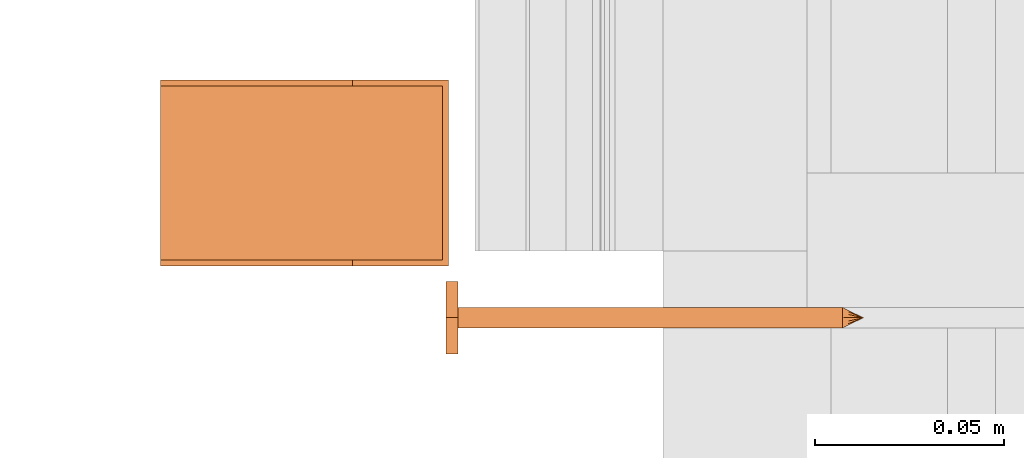
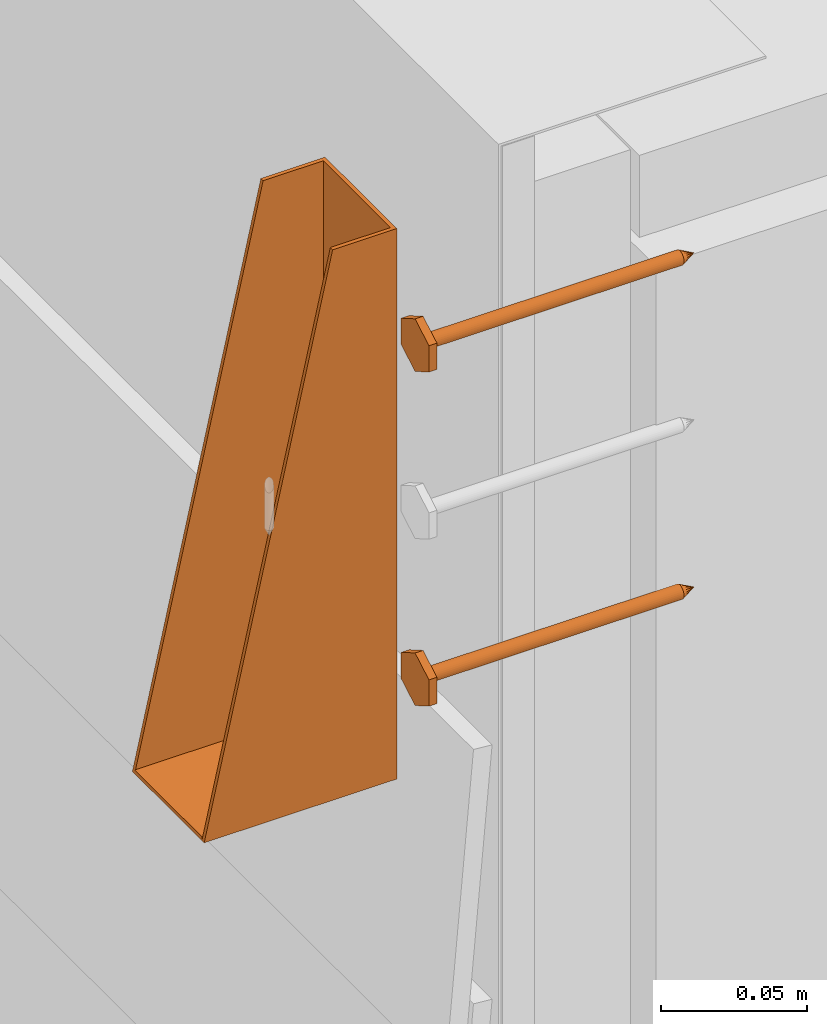
# One storey, part 17 of 44: 3 proxies.
"""IFC4 building model written with IfcOpenShell, lengths in feet."""

from ifc_helpers import new_model, entity, si_unit, converted_unit, derived_unit, direction, frame, frame_2d, origin, origin_2d_with_axis, place, context, subcontext, project, spatial, polyline, rectangle, outline, extrude, source, transform, mapped, material, type_object, type_shapes, element, save


model = new_model("IFC4")

# Units and contexts
model_context = context("Model", 3, precision=0.0001, world=origin(), true_north=direction((6.12303176911189e-17, 1.0)))
body_context = subcontext(model_context, "Body", "Model", "MODEL_VIEW")
ifc_project = project(units=[converted_unit("LENGTHUNIT", "FOOT", entity("IfcRatioMeasure", 0.3048), si_unit("LENGTHUNIT", "METRE"), dimensions=[1, 0, 0, 0, 0, 0, 0]), converted_unit("AREAUNIT", "SQUARE FOOT", entity("IfcRatioMeasure", 0.09290304), si_unit("AREAUNIT", "SQUARE_METRE"), dimensions=[2, 0, 0, 0, 0, 0, 0]), converted_unit("VOLUMEUNIT", "CUBIC FOOT", entity("IfcRatioMeasure", 0.028316846592), si_unit("VOLUMEUNIT", "CUBIC_METRE"), dimensions=[3, 0, 0, 0, 0, 0, 0]), converted_unit("PLANEANGLEUNIT", "DEGREE", entity("IfcRatioMeasure", 0.0174532925199433), si_unit("PLANEANGLEUNIT", "RADIAN"), dimensions=[0, 0, 0, 0, 0, 0, 0]), si_unit("MASSUNIT", "GRAM", prefix="KILO"), derived_unit("MASSDENSITYUNIT", [(si_unit("MASSUNIT", "GRAM", prefix="KILO"), 1), (si_unit("LENGTHUNIT", "METRE"), -3)]), derived_unit("MOMENTOFINERTIAUNIT", [(si_unit("LENGTHUNIT", "METRE"), 4)]), si_unit("TIMEUNIT", "SECOND"), si_unit("FREQUENCYUNIT", "HERTZ"), si_unit("THERMODYNAMICTEMPERATUREUNIT", "DEGREE_CELSIUS"), derived_unit("THERMALTRANSMITTANCEUNIT", [(si_unit("MASSUNIT", "GRAM", prefix="KILO"), 1), (si_unit("THERMODYNAMICTEMPERATUREUNIT", "KELVIN"), -1), (si_unit("TIMEUNIT", "SECOND"), -3)]), derived_unit("VOLUMETRICFLOWRATEUNIT", [(si_unit("LENGTHUNIT", "METRE"), 3), (si_unit("TIMEUNIT", "SECOND"), -1)]), si_unit("ELECTRICCURRENTUNIT", "AMPERE"), si_unit("ELECTRICVOLTAGEUNIT", "VOLT"), si_unit("POWERUNIT", "WATT"), si_unit("FORCEUNIT", "NEWTON"), si_unit("ILLUMINANCEUNIT", "LUX"), si_unit("LUMINOUSFLUXUNIT", "LUMEN"), si_unit("LUMINOUSINTENSITYUNIT", "CANDELA"), derived_unit("USERDEFINED", [(si_unit("MASSUNIT", "GRAM", prefix="KILO"), -1), (si_unit("LENGTHUNIT", "METRE"), -2), (si_unit("TIMEUNIT", "SECOND"), 3), (si_unit("LUMINOUSFLUXUNIT", "LUMEN"), 1)]), derived_unit("LINEARVELOCITYUNIT", [(si_unit("LENGTHUNIT", "METRE"), 1), (si_unit("TIMEUNIT", "SECOND"), -1)]), si_unit("PRESSUREUNIT", "PASCAL"), derived_unit("USERDEFINED", [(si_unit("LENGTHUNIT", "METRE"), -2), (si_unit("MASSUNIT", "GRAM", prefix="KILO"), 1), (si_unit("TIMEUNIT", "SECOND"), -2)]), derived_unit("LINEARFORCEUNIT", [(si_unit("MASSUNIT", "GRAM", prefix="KILO"), 1), (si_unit("LENGTHUNIT", "METRE"), 1), (si_unit("TIMEUNIT", "SECOND"), -2), (si_unit("LENGTHUNIT", "METRE"), -1)]), derived_unit("PLANARFORCEUNIT", [(si_unit("MASSUNIT", "GRAM", prefix="KILO"), 1), (si_unit("LENGTHUNIT", "METRE"), 1), (si_unit("TIMEUNIT", "SECOND"), -2), (si_unit("LENGTHUNIT", "METRE"), -2)])], contexts=[model_context])

# Site, building, storey
site_placement = place(None, origin())
site = spatial("IfcSite", under=ifc_project, at=site_placement, CompositionType="ELEMENT")
building_placement = place(site_placement, origin())
building = spatial("IfcBuilding", under=site, at=building_placement, CompositionType="ELEMENT")
storey_placement = place(building_placement, origin())
storey = spatial("IfcBuildingStorey", under=building, at=storey_placement, CompositionType="ELEMENT", Elevation=0.0)

# Proxies
ifc_material_1 = material(Name="STRONG-DRIVE TIMBER SCREW (EXTERIOR GRADE)", Category="Materials")
building_element_proxy_type_1 = type_object("IfcBuildingElementProxyType", PredefinedType="NOTDEFINED", material=ifc_material_1)
cartesian_point_1 = entity("IfcCartesianPoint", [0.0, -0.00916666666677942, -0.333333333333231])
vertex_point_1 = entity("IfcVertexPoint", cartesian_point_1)
cartesian_point_2 = entity("IfcCartesianPoint", [0.0, 0.00916666666667798, -0.333333333333232])
vertex_point_2 = entity("IfcVertexPoint", cartesian_point_2)
cartesian_point_3 = entity("IfcCartesianPoint", [0.0, 0.0, -0.333333333333232])
ifc_direction_1 = entity("IfcDirection", [0.0, 0.0, 1.0])
ifc_direction_2 = entity("IfcDirection", [0.0, 1.0, 0.0])
edge_curve_1 = entity("IfcEdgeCurve", vertex_point_1, vertex_point_2, entity("IfcTrimmedCurve", entity("IfcCircle", entity("IfcAxis2Placement3D", cartesian_point_3, ifc_direction_1, ifc_direction_2), 0.0091666666667287), [cartesian_point_1], [cartesian_point_2], True, "CARTESIAN"), True)
vertex_point_3 = entity("IfcVertexPoint", cartesian_point_3)
ifc_direction_3 = entity("IfcDirection", [0.0, -1.0, 0.0])
edge_curve_2 = entity("IfcEdgeCurve", vertex_point_2, vertex_point_3, entity("IfcTrimmedCurve", entity("IfcLine", cartesian_point_2, entity("IfcVector", ifc_direction_3, 1.0)), [cartesian_point_2], [cartesian_point_3], True, "CARTESIAN"), True)
edge_curve_3 = entity("IfcEdgeCurve", vertex_point_3, vertex_point_1, entity("IfcTrimmedCurve", entity("IfcLine", cartesian_point_3, entity("IfcVector", ifc_direction_3, 1.0)), [cartesian_point_3], [cartesian_point_1], True, "CARTESIAN"), True)
edge_curve_4 = entity("IfcEdgeCurve", vertex_point_2, vertex_point_1, entity("IfcTrimmedCurve", entity("IfcCircle", entity("IfcAxis2Placement3D", cartesian_point_3, ifc_direction_1, ifc_direction_2), 0.0091666666667287), [cartesian_point_2], [cartesian_point_1], True, "CARTESIAN"), True)
cartesian_point_4 = entity("IfcCartesianPoint", [0.0, 0.0, -0.351666666666333])
vertex_point_4 = entity("IfcVertexPoint", cartesian_point_4)
edge_curve_5 = entity("IfcEdgeCurve", vertex_point_4, vertex_point_2, entity("IfcTrimmedCurve", entity("IfcLine", cartesian_point_4, entity("IfcVector", entity("IfcDirection", [0.0, 0.447213595507238, 0.894427190996276]), 1.0)), [cartesian_point_4], [cartesian_point_2], True, "CARTESIAN"), True)
edge_curve_6 = entity("IfcEdgeCurve", vertex_point_1, vertex_point_4, entity("IfcTrimmedCurve", entity("IfcLine", cartesian_point_1, entity("IfcVector", entity("IfcDirection", [0.0, 0.447213595507224, -0.894427190996283]), 1.0)), [cartesian_point_1], [cartesian_point_4], True, "CARTESIAN"), True)
cartesian_point_5 = entity("IfcCartesianPoint", [-0.00916666666669726, 0.0, -0.333333333333231])
cartesian_point_6 = entity("IfcCartesianPoint", [0.0, 0.0, -0.338202184590857])
ifc_direction_4 = entity("IfcDirection", [0.0, 0.0, -1.0])
cartesian_point_7 = entity("IfcCartesianPoint", [-0.0312499999999625, 0.0180421959120341, 0.0104166666670403])
vertex_point_5 = entity("IfcVertexPoint", cartesian_point_7)
cartesian_point_8 = entity("IfcCartesianPoint", [-0.0312499999999625, -0.0180421959123371, 0.0104166666670405])
vertex_point_6 = entity("IfcVertexPoint", cartesian_point_8)
ifc_direction_5 = entity("IfcDirection", [0.0, -1.0, 0.0])
edge_curve_7 = entity("IfcEdgeCurve", vertex_point_5, vertex_point_6, entity("IfcTrimmedCurve", entity("IfcLine", cartesian_point_7, entity("IfcVector", ifc_direction_5, 1.0)), [cartesian_point_7], [cartesian_point_8], True, "CARTESIAN"), True)
cartesian_point_9 = entity("IfcCartesianPoint", [0.0, -0.0360843918245031, 0.0104166666670406])
vertex_point_7 = entity("IfcVertexPoint", cartesian_point_9)
edge_curve_8 = entity("IfcEdgeCurve", vertex_point_6, vertex_point_7, entity("IfcTrimmedCurve", entity("IfcLine", cartesian_point_8, entity("IfcVector", entity("IfcDirection", [0.866025403784438, -0.500000000000001, 0.0]), 1.0)), [cartesian_point_8], [cartesian_point_9], True, "CARTESIAN"), True)
cartesian_point_10 = entity("IfcCartesianPoint", [0.0312500000000785, -0.0180421959122939, 0.0104166666670405])
vertex_point_8 = entity("IfcVertexPoint", cartesian_point_10)
edge_curve_9 = entity("IfcEdgeCurve", vertex_point_7, vertex_point_8, entity("IfcTrimmedCurve", entity("IfcLine", cartesian_point_9, entity("IfcVector", entity("IfcDirection", [0.86602540378444, 0.499999999999998, 0.0]), 1.0)), [cartesian_point_9], [cartesian_point_10], True, "CARTESIAN"), True)
cartesian_point_11 = entity("IfcCartesianPoint", [0.0312500000000786, 0.0180421959119906, 0.0104166666670403])
vertex_point_9 = entity("IfcVertexPoint", cartesian_point_11)
ifc_direction_6 = entity("IfcDirection", [0.0, 1.0, 0.0])
edge_curve_10 = entity("IfcEdgeCurve", vertex_point_8, vertex_point_9, entity("IfcTrimmedCurve", entity("IfcLine", cartesian_point_10, entity("IfcVector", ifc_direction_6, 1.0)), [cartesian_point_10], [cartesian_point_11], True, "CARTESIAN"), True)
cartesian_point_12 = entity("IfcCartesianPoint", [0.0, 0.0360843918242001, 0.0104166666670402])
vertex_point_10 = entity("IfcVertexPoint", cartesian_point_12)
edge_curve_11 = entity("IfcEdgeCurve", vertex_point_9, vertex_point_10, entity("IfcTrimmedCurve", entity("IfcLine", cartesian_point_11, entity("IfcVector", entity("IfcDirection", [-0.866025403784436, 0.500000000000004, 0.0]), 1.0)), [cartesian_point_11], [cartesian_point_12], True, "CARTESIAN"), True)
edge_curve_12 = entity("IfcEdgeCurve", vertex_point_10, vertex_point_5, entity("IfcTrimmedCurve", entity("IfcLine", cartesian_point_12, entity("IfcVector", entity("IfcDirection", [-0.866025403784438, -0.500000000000001, 0.0]), 1.0)), [cartesian_point_12], [cartesian_point_7], True, "CARTESIAN"), True)
ifc_direction_7 = entity("IfcDirection", [0.0, 0.0, 1.0])
cartesian_point_13 = entity("IfcCartesianPoint", [-0.0312499999999625, 0.018042195912034, 0.0])
vertex_point_11 = entity("IfcVertexPoint", cartesian_point_13)
cartesian_point_14 = entity("IfcCartesianPoint", [0.0, 0.0360843918242001, 0.0])
vertex_point_12 = entity("IfcVertexPoint", cartesian_point_14)
edge_curve_13 = entity("IfcEdgeCurve", vertex_point_11, vertex_point_12, entity("IfcTrimmedCurve", entity("IfcLine", cartesian_point_13, entity("IfcVector", entity("IfcDirection", [0.866025403784438, 0.500000000000001, 0.0]), 1.0)), [cartesian_point_13], [cartesian_point_14], True, "CARTESIAN"), True)
cartesian_point_15 = entity("IfcCartesianPoint", [0.0312500000000786, 0.0180421959119905, 0.0])
vertex_point_13 = entity("IfcVertexPoint", cartesian_point_15)
edge_curve_14 = entity("IfcEdgeCurve", vertex_point_12, vertex_point_13, entity("IfcTrimmedCurve", entity("IfcLine", cartesian_point_14, entity("IfcVector", entity("IfcDirection", [0.866025403784437, -0.500000000000004, 0.0]), 1.0)), [cartesian_point_14], [cartesian_point_15], True, "CARTESIAN"), True)
cartesian_point_16 = entity("IfcCartesianPoint", [0.0312500000000785, -0.0180421959122939, 0.0])
vertex_point_14 = entity("IfcVertexPoint", cartesian_point_16)
edge_curve_15 = entity("IfcEdgeCurve", vertex_point_13, vertex_point_14, entity("IfcTrimmedCurve", entity("IfcLine", cartesian_point_15, entity("IfcVector", ifc_direction_5, 1.0)), [cartesian_point_15], [cartesian_point_16], True, "CARTESIAN"), True)
cartesian_point_17 = entity("IfcCartesianPoint", [0.0, -0.0360843918245032, 0.0])
vertex_point_15 = entity("IfcVertexPoint", cartesian_point_17)
edge_curve_16 = entity("IfcEdgeCurve", vertex_point_14, vertex_point_15, entity("IfcTrimmedCurve", entity("IfcLine", cartesian_point_16, entity("IfcVector", entity("IfcDirection", [-0.86602540378444, -0.499999999999998, 0.0]), 1.0)), [cartesian_point_16], [cartesian_point_17], True, "CARTESIAN"), True)
cartesian_point_18 = entity("IfcCartesianPoint", [-0.0312499999999625, -0.0180421959123372, 0.0])
vertex_point_16 = entity("IfcVertexPoint", cartesian_point_18)
edge_curve_17 = entity("IfcEdgeCurve", vertex_point_15, vertex_point_16, entity("IfcTrimmedCurve", entity("IfcLine", cartesian_point_17, entity("IfcVector", entity("IfcDirection", [-0.866025403784438, 0.500000000000001, 0.0]), 1.0)), [cartesian_point_17], [cartesian_point_18], True, "CARTESIAN"), True)
edge_curve_18 = entity("IfcEdgeCurve", vertex_point_16, vertex_point_11, entity("IfcTrimmedCurve", entity("IfcLine", cartesian_point_18, entity("IfcVector", ifc_direction_6, 1.0)), [cartesian_point_18], [cartesian_point_13], True, "CARTESIAN"), True)
ifc_direction_8 = entity("IfcDirection", [0.0, 0.0, -1.0])
edge_curve_19 = entity("IfcEdgeCurve", vertex_point_5, vertex_point_11, entity("IfcTrimmedCurve", entity("IfcLine", cartesian_point_7, entity("IfcVector", ifc_direction_8, 1.0)), [cartesian_point_7], [cartesian_point_13], True, "CARTESIAN"), True)
edge_curve_20 = entity("IfcEdgeCurve", vertex_point_16, vertex_point_6, entity("IfcTrimmedCurve", entity("IfcLine", cartesian_point_8, entity("IfcVector", ifc_direction_7, 1.0)), [cartesian_point_18], [cartesian_point_8], True, "CARTESIAN"), True)
edge_curve_21 = entity("IfcEdgeCurve", vertex_point_15, vertex_point_7, entity("IfcTrimmedCurve", entity("IfcLine", cartesian_point_9, entity("IfcVector", ifc_direction_7, 1.0)), [cartesian_point_17], [cartesian_point_9], True, "CARTESIAN"), True)
edge_curve_22 = entity("IfcEdgeCurve", vertex_point_14, vertex_point_8, entity("IfcTrimmedCurve", entity("IfcLine", cartesian_point_10, entity("IfcVector", ifc_direction_7, 1.0)), [cartesian_point_16], [cartesian_point_10], True, "CARTESIAN"), True)
edge_curve_23 = entity("IfcEdgeCurve", vertex_point_13, vertex_point_9, entity("IfcTrimmedCurve", entity("IfcLine", cartesian_point_11, entity("IfcVector", ifc_direction_7, 1.0)), [cartesian_point_15], [cartesian_point_11], True, "CARTESIAN"), True)
edge_curve_24 = entity("IfcEdgeCurve", vertex_point_12, vertex_point_10, entity("IfcTrimmedCurve", entity("IfcLine", cartesian_point_12, entity("IfcVector", ifc_direction_7, 1.0)), [cartesian_point_14], [cartesian_point_12], True, "CARTESIAN"), True)
cartesian_point_19 = entity("IfcCartesianPoint", [0.0, -0.00916666666682102, 0.0])
vertex_point_17 = entity("IfcVertexPoint", cartesian_point_19)
cartesian_point_20 = entity("IfcCartesianPoint", [0.0, 0.00916666666651231, 0.0])
vertex_point_18 = entity("IfcVertexPoint", cartesian_point_20)
cartesian_point_21 = entity("IfcCartesianPoint", [0.0, 0.0, 0.0])
ifc_direction_9 = entity("IfcDirection", [0.0, 0.0, 1.0])
ifc_direction_10 = entity("IfcDirection", [0.0, 1.0, 0.0])
edge_curve_25 = entity("IfcEdgeCurve", vertex_point_17, vertex_point_18, entity("IfcTrimmedCurve", entity("IfcCircle", entity("IfcAxis2Placement3D", cartesian_point_21, ifc_direction_9, ifc_direction_10), 0.00916666666666667), [cartesian_point_19], [cartesian_point_20], True, "CARTESIAN"), True)
edge_curve_26 = entity("IfcEdgeCurve", vertex_point_18, vertex_point_17, entity("IfcTrimmedCurve", entity("IfcCircle", entity("IfcAxis2Placement3D", cartesian_point_21, ifc_direction_9, ifc_direction_10), 0.00916666666666667), [cartesian_point_20], [cartesian_point_19], True, "CARTESIAN"), True)
cartesian_point_22 = entity("IfcCartesianPoint", [0.0, -0.00916666666682389, -0.333333333333339])
vertex_point_19 = entity("IfcVertexPoint", cartesian_point_22)
cartesian_point_23 = entity("IfcCartesianPoint", [0.0, 0.00916666666650944, -0.333333333333339])
vertex_point_20 = entity("IfcVertexPoint", cartesian_point_23)
cartesian_point_24 = entity("IfcCartesianPoint", [0.0, 0.0, -0.333333333333339])
ifc_direction_11 = entity("IfcDirection", [0.0, 0.0, -1.0])
edge_curve_27 = entity("IfcEdgeCurve", vertex_point_19, vertex_point_20, entity("IfcTrimmedCurve", entity("IfcCircle", entity("IfcAxis2Placement3D", cartesian_point_24, ifc_direction_11, ifc_direction_10), 0.00916666666666667), [cartesian_point_22], [cartesian_point_23], True, "CARTESIAN"), True)
edge_curve_28 = entity("IfcEdgeCurve", vertex_point_20, vertex_point_19, entity("IfcTrimmedCurve", entity("IfcCircle", entity("IfcAxis2Placement3D", cartesian_point_24, ifc_direction_11, ifc_direction_10), 0.00916666666666667), [cartesian_point_23], [cartesian_point_22], True, "CARTESIAN"), True)
edge_curve_29 = entity("IfcEdgeCurve", vertex_point_17, vertex_point_19, entity("IfcTrimmedCurve", entity("IfcLine", cartesian_point_19, entity("IfcVector", ifc_direction_11, 1.0)), [cartesian_point_19], [cartesian_point_22], True, "CARTESIAN"), True)
edge_curve_30 = entity("IfcEdgeCurve", vertex_point_20, vertex_point_18, entity("IfcTrimmedCurve", entity("IfcLine", cartesian_point_20, entity("IfcVector", ifc_direction_9, 1.0)), [cartesian_point_23], [cartesian_point_20], True, "CARTESIAN"), True)
shared_shape_1 = source(origin(), body_context, "Body", "AdvancedBrep", [
    entity("IfcAdvancedBrep", entity("IfcClosedShell", [entity("IfcAdvancedFace", [entity("IfcFaceOuterBound", entity("IfcEdgeLoop", [entity("IfcOrientedEdge", None, None, edge_curve_1, True), entity("IfcOrientedEdge", None, None, edge_curve_2, True), entity("IfcOrientedEdge", None, None, edge_curve_3, True)]), True)], entity("IfcPlane", entity("IfcAxis2Placement3D", cartesian_point_3, ifc_direction_1, ifc_direction_2)), True), entity("IfcAdvancedFace", [entity("IfcFaceOuterBound", entity("IfcEdgeLoop", [entity("IfcOrientedEdge", None, None, edge_curve_4, True), entity("IfcOrientedEdge", None, None, edge_curve_3, False), entity("IfcOrientedEdge", None, None, edge_curve_2, False)]), True)], entity("IfcPlane", entity("IfcAxis2Placement3D", cartesian_point_3, ifc_direction_1, ifc_direction_2)), True), entity("IfcAdvancedFace", [entity("IfcFaceOuterBound", entity("IfcEdgeLoop", [entity("IfcOrientedEdge", None, None, edge_curve_5, True), entity("IfcOrientedEdge", None, None, edge_curve_1, False), entity("IfcOrientedEdge", None, None, edge_curve_6, True)]), True)], entity("IfcSurfaceOfRevolution", entity("IfcArbitraryOpenProfileDef", "CURVE", None, entity("IfcTrimmedCurve", entity("IfcLine", cartesian_point_4, entity("IfcVector", entity("IfcDirection", [0.447213595507221, 0.0, -0.894427190996284]), 1.0)), [cartesian_point_5], [cartesian_point_4], True, "CARTESIAN")), None, entity("IfcAxis1Placement", cartesian_point_6, ifc_direction_4)), True), entity("IfcAdvancedFace", [entity("IfcFaceOuterBound", entity("IfcEdgeLoop", [entity("IfcOrientedEdge", None, None, edge_curve_6, False), entity("IfcOrientedEdge", None, None, edge_curve_4, False), entity("IfcOrientedEdge", None, None, edge_curve_5, False)]), True)], entity("IfcSurfaceOfRevolution", entity("IfcArbitraryOpenProfileDef", "CURVE", None, entity("IfcTrimmedCurve", entity("IfcLine", cartesian_point_4, entity("IfcVector", entity("IfcDirection", [0.447213595507221, 0.0, -0.894427190996284]), 1.0)), [cartesian_point_5], [cartesian_point_4], True, "CARTESIAN")), None, entity("IfcAxis1Placement", cartesian_point_6, ifc_direction_4)), True)])),
    entity("IfcAdvancedBrep", entity("IfcClosedShell", [entity("IfcAdvancedFace", [entity("IfcFaceOuterBound", entity("IfcEdgeLoop", [entity("IfcOrientedEdge", None, None, edge_curve_7, True), entity("IfcOrientedEdge", None, None, edge_curve_8, True), entity("IfcOrientedEdge", None, None, edge_curve_9, True), entity("IfcOrientedEdge", None, None, edge_curve_10, True), entity("IfcOrientedEdge", None, None, edge_curve_11, True), entity("IfcOrientedEdge", None, None, edge_curve_12, True)]), True)], entity("IfcPlane", entity("IfcAxis2Placement3D", cartesian_point_7, ifc_direction_7, ifc_direction_5)), True), entity("IfcAdvancedFace", [entity("IfcFaceOuterBound", entity("IfcEdgeLoop", [entity("IfcOrientedEdge", None, None, edge_curve_13, True), entity("IfcOrientedEdge", None, None, edge_curve_14, True), entity("IfcOrientedEdge", None, None, edge_curve_15, True), entity("IfcOrientedEdge", None, None, edge_curve_16, True), entity("IfcOrientedEdge", None, None, edge_curve_17, True), entity("IfcOrientedEdge", None, None, edge_curve_18, True)]), True)], entity("IfcPlane", entity("IfcAxis2Placement3D", cartesian_point_13, ifc_direction_8, ifc_direction_6)), True), entity("IfcAdvancedFace", [entity("IfcFaceOuterBound", entity("IfcEdgeLoop", [entity("IfcOrientedEdge", None, None, edge_curve_7, False), entity("IfcOrientedEdge", None, None, edge_curve_19, True), entity("IfcOrientedEdge", None, None, edge_curve_18, False), entity("IfcOrientedEdge", None, None, edge_curve_20, True)]), True)], entity("IfcPlane", entity("IfcAxis2Placement3D", cartesian_point_7, entity("IfcDirection", [-1.0, 0.0, 0.0]), ifc_direction_8)), True), entity("IfcAdvancedFace", [entity("IfcFaceOuterBound", entity("IfcEdgeLoop", [entity("IfcOrientedEdge", None, None, edge_curve_8, False), entity("IfcOrientedEdge", None, None, edge_curve_20, False), entity("IfcOrientedEdge", None, None, edge_curve_17, False), entity("IfcOrientedEdge", None, None, edge_curve_21, True)]), True)], entity("IfcPlane", entity("IfcAxis2Placement3D", cartesian_point_8, entity("IfcDirection", [-0.500000000000001, -0.866025403784438, 0.0]), ifc_direction_8)), True), entity("IfcAdvancedFace", [entity("IfcFaceOuterBound", entity("IfcEdgeLoop", [entity("IfcOrientedEdge", None, None, edge_curve_9, False), entity("IfcOrientedEdge", None, None, edge_curve_21, False), entity("IfcOrientedEdge", None, None, edge_curve_16, False), entity("IfcOrientedEdge", None, None, edge_curve_22, True)]), True)], entity("IfcPlane", entity("IfcAxis2Placement3D", cartesian_point_9, entity("IfcDirection", [0.499999999999998, -0.86602540378444, 0.0]), ifc_direction_8)), True), entity("IfcAdvancedFace", [entity("IfcFaceOuterBound", entity("IfcEdgeLoop", [entity("IfcOrientedEdge", None, None, edge_curve_10, False), entity("IfcOrientedEdge", None, None, edge_curve_22, False), entity("IfcOrientedEdge", None, None, edge_curve_15, False), entity("IfcOrientedEdge", None, None, edge_curve_23, True)]), True)], entity("IfcPlane", entity("IfcAxis2Placement3D", cartesian_point_10, entity("IfcDirection", [1.0, 0.0, 0.0]), ifc_direction_8)), True), entity("IfcAdvancedFace", [entity("IfcFaceOuterBound", entity("IfcEdgeLoop", [entity("IfcOrientedEdge", None, None, edge_curve_11, False), entity("IfcOrientedEdge", None, None, edge_curve_23, False), entity("IfcOrientedEdge", None, None, edge_curve_14, False), entity("IfcOrientedEdge", None, None, edge_curve_24, True)]), True)], entity("IfcPlane", entity("IfcAxis2Placement3D", cartesian_point_11, entity("IfcDirection", [0.500000000000003, 0.866025403784437, 0.0]), ifc_direction_8)), True), entity("IfcAdvancedFace", [entity("IfcFaceOuterBound", entity("IfcEdgeLoop", [entity("IfcOrientedEdge", None, None, edge_curve_12, False), entity("IfcOrientedEdge", None, None, edge_curve_24, False), entity("IfcOrientedEdge", None, None, edge_curve_13, False), entity("IfcOrientedEdge", None, None, edge_curve_19, False)]), True)], entity("IfcPlane", entity("IfcAxis2Placement3D", cartesian_point_12, entity("IfcDirection", [-0.500000000000001, 0.866025403784438, 0.0]), ifc_direction_8)), True)])),
    entity("IfcAdvancedBrep", entity("IfcClosedShell", [entity("IfcAdvancedFace", [entity("IfcFaceOuterBound", entity("IfcEdgeLoop", [entity("IfcOrientedEdge", None, None, edge_curve_25, True), entity("IfcOrientedEdge", None, None, edge_curve_26, True)]), True)], entity("IfcPlane", entity("IfcAxis2Placement3D", cartesian_point_20, ifc_direction_9, entity("IfcDirection", [-1.0, 0.0, 0.0]))), True), entity("IfcAdvancedFace", [entity("IfcFaceOuterBound", entity("IfcEdgeLoop", [entity("IfcOrientedEdge", None, None, edge_curve_27, True), entity("IfcOrientedEdge", None, None, edge_curve_28, True)]), True)], entity("IfcPlane", entity("IfcAxis2Placement3D", cartesian_point_23, ifc_direction_11, entity("IfcDirection", [1.0, 0.0, 0.0]))), True), entity("IfcAdvancedFace", [entity("IfcFaceOuterBound", entity("IfcEdgeLoop", [entity("IfcOrientedEdge", None, None, edge_curve_25, False), entity("IfcOrientedEdge", None, None, edge_curve_29, True), entity("IfcOrientedEdge", None, None, edge_curve_28, False), entity("IfcOrientedEdge", None, None, edge_curve_30, True)]), True)], entity("IfcCylindricalSurface", entity("IfcAxis2Placement3D", cartesian_point_24, ifc_direction_9, ifc_direction_10), 0.00916666666666667), True), entity("IfcAdvancedFace", [entity("IfcFaceOuterBound", entity("IfcEdgeLoop", [entity("IfcOrientedEdge", None, None, edge_curve_26, False), entity("IfcOrientedEdge", None, None, edge_curve_30, False), entity("IfcOrientedEdge", None, None, edge_curve_27, False), entity("IfcOrientedEdge", None, None, edge_curve_29, False)]), True)], entity("IfcCylindricalSurface", entity("IfcAxis2Placement3D", cartesian_point_24, ifc_direction_9, ifc_direction_10), 0.00916666666666667), True)])),
])
type_shapes(building_element_proxy_type_1, [shared_shape_1])
for number, where, z_axis, x_axis in (
    (1, (1459.13314342118, 1.94204634015957, 10.0228223495324), (-1.0, 0.0, 0.0), (0.0, 1.0, 0.0)),
    (2, (1459.13314342118, 1.94204634015957, 10.4811556828658), (-1.0, 0.0, 0.0), (0.0, 1.0, 0.0)),
):
    element("IfcBuildingElementProxy", number, at=place(storey_placement, frame(where, z_axis=z_axis, x_axis=x_axis)), inside=storey, type_object=building_element_proxy_type_1, material=ifc_material_1, PredefinedType="NOTDEFINED", context=body_context, shape_type="MappedRepresentation", body=[
        mapped(shared_shape_1, transform((0.0, 0.0, 0.0), scale=1.0)),
    ])
ifc_material_2 = material(Name="HUC46 JOIST HANGER WITH CONCEALED HDG - UNPAINTED", Category="Materials")
building_element_proxy_type_2 = type_object("IfcBuildingElementProxyType", Name="050523 - Metal Joist Hanger - Generic:1.81/9-SDS", PredefinedType="NOTDEFINED", material=ifc_material_2)
shared_shape_2 = source(origin(), body_context, "Body", "SweptSolid", [
    extrude(outline(polyline([(-0.377604166666657, -0.0833333333333589), (0.377604166666657, -0.0833333333333589), (0.377604166666657, 0.0), (-0.377604166666657, 0.166666666666694), (-0.377604166666657, -0.0833333333333589)])), frame((-0.0807291666666463, -0.0833333333333328, 0.372395833333338), z_axis=(1.0, 0.0, 0.0), x_axis=(0.0, 0.0, 1.0)), (0.0, 0.0, 1.0), 0.00520833333333333),
    extrude(outline(polyline([(-0.377604166666661, -0.0833333333333546), (0.377604166666661, -0.0833333333333546), (0.377604166666661, 0.0), (-0.377604166666661, 0.166666666666692), (-0.377604166666661, -0.0833333333333546)])), frame((0.0755208333333537, -0.0833333333333374, 0.372395833333333), z_axis=(1.0, 0.0, 0.0), x_axis=(0.0, 0.0, 1.0)), (0.0, 0.0, 1.0), 0.00520833333333333),
    extrude(rectangle(XDim=0.00520833333329789, YDim=0.104166666666653, at=origin_2d_with_axis()), frame((0.0234375000000141, -0.00260416666671204, 0.0), z_axis=(0.0, 0.0, 1.0), x_axis=(0.0, 1.0, 0.0)), (0.0, 0.0, 1.0), 0.750000000000093),
    extrude(rectangle(XDim=0.00520833333329789, YDim=0.104166666666656, at=origin_2d_with_axis()), frame((-0.0234375000000063, -0.00260416666671204, 0.0), z_axis=(0.0, 0.0, 1.0), x_axis=(0.0, 1.0, 0.0)), (0.0, 0.0, 1.0), 0.750000000000097),
    extrude(rectangle(XDim=0.250000000000316, YDim=0.151041666666731, at=frame_2d((-2.77555756156289e-17, -6.93889390390723e-18), x_axis=(1.0, 0.0))), frame((0.0, -0.125000000000474, -0.00520833333333946), z_axis=(0.0, 0.0, 1.0), x_axis=(0.0, -1.0, 0.0)), (0.0, 0.0, 1.0), 0.00520833333333333),
])
type_shapes(building_element_proxy_type_2, [shared_shape_2])
proxy_placement = place(storey_placement, frame((1459.12506713878, 2.06770833332917, 9.86310254279066), z_axis=(0.0, 0.0, 1.0), x_axis=(0.0, -1.0, 0.0)))
element("IfcBuildingElementProxy", 3, at=proxy_placement, inside=storey, type_object=building_element_proxy_type_2, material=ifc_material_2, Name="050523 - Metal Joist Hanger - Generic:1.81/9", ObjectType="050523 - Metal Joist Hanger - Generic:1.81/9-SDS", PredefinedType="NOTDEFINED", context=body_context, shape_type="MappedRepresentation", body=[
    mapped(shared_shape_2, transform((0.0, 0.0, 0.0), scale=1.0)),
])

save(model, "model.ifc")
